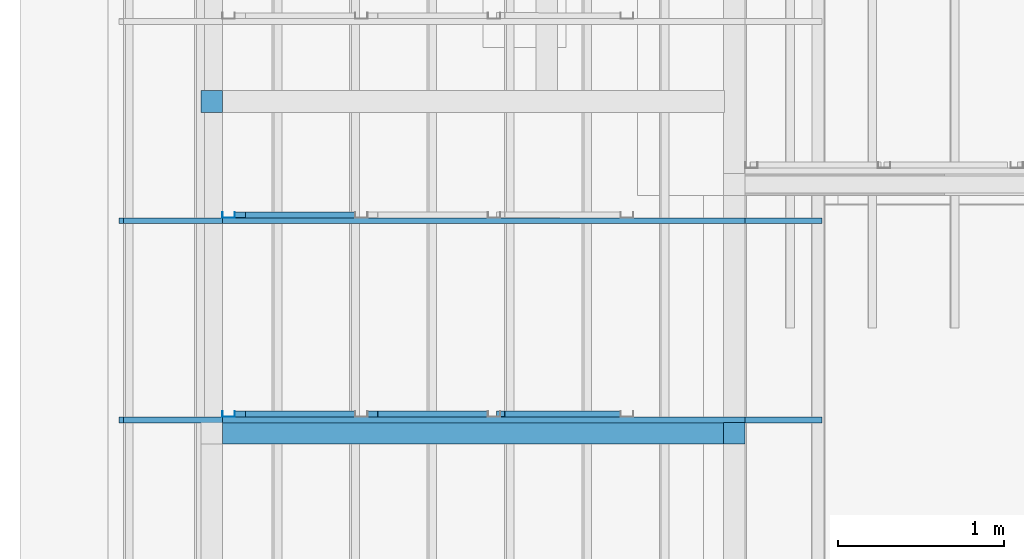
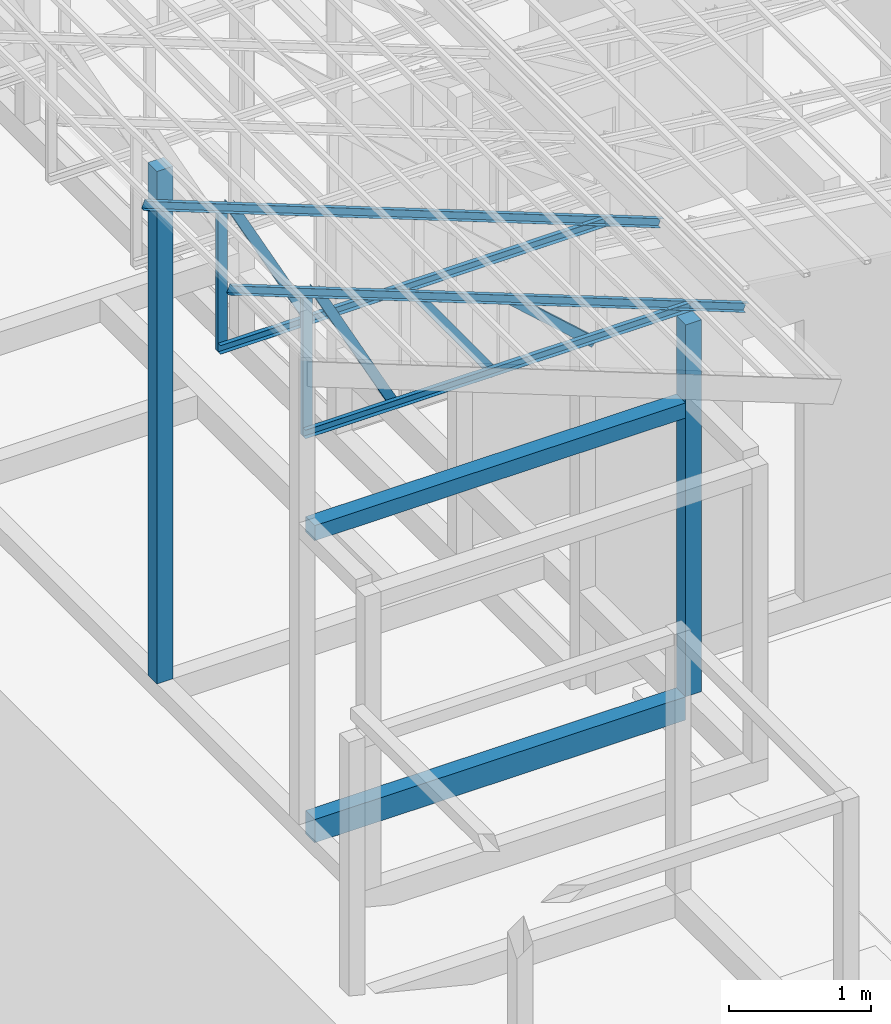
# One storey, part 3 of 22: 10 members, 4 beams, 1 element without a shape of its own.
"""IFC4 building model written with IfcOpenShell, lengths in millimetres."""

from ifc_helpers import new_model, entity, si_unit, converted_unit, frame, origin_with_axes, origin_2d_with_axis, place, context, subcontext, project, spatial, indexed_curve, rectangle, c_section, outline, extrude, material, material_profile, profile_set, profile_usage, type_object, element, aggregate, save


model = new_model("IFC4")

# Units and contexts
model_context = context("Model", 3, precision=1e-05, world=origin_with_axes())
plan_context = context("Plan", 2, precision=1e-05, world=origin_2d_with_axis())
body_context = subcontext(model_context, "Body", "Model", "MODEL_VIEW")
ifc_project = project(units=[si_unit("VOLUMEUNIT", "CUBIC_METRE"), si_unit("LENGTHUNIT", "METRE", prefix="MILLI"), si_unit("AREAUNIT", "SQUARE_METRE"), converted_unit("PLANEANGLEUNIT", "degree", entity("IfcReal", 0.0174532925199433), si_unit("PLANEANGLEUNIT", "RADIAN"), dimensions=[0, 0, 0, 0, 0, 0, 0])], contexts=[model_context, plan_context])

# Site, building, storey
site_placement = place(None, origin_with_axes())
site = spatial("IfcSite", under=ifc_project, at=site_placement)
building_placement = place(site_placement, origin_with_axes())
building = spatial("IfcBuilding", under=site, at=building_placement, Name="2")
storey_placement = place(building_placement, frame((0.0, 0.0, 200.000002980232), z_axis=(0.0, 0.0, 1.0), x_axis=(1.0, 0.0, 0.0)))
storey = spatial("IfcBuildingStorey", under=building, at=storey_placement)

# Beams
ifc_material_1 = material(Name="Concrete")
ifc_material_profile_1 = material_profile(ifc_material_1, outline(indexed_curve([(-65.0, 99.9999923706055), (65.0, 99.9999923706055), (65.0, -99.9999923706055), (-65.0, -99.9999923706055), (-65.0, 99.9999923706055)])))
ifc_profile_set_1 = profile_set([ifc_material_profile_1])
ifc_profile_usage_1 = profile_usage(ifc_profile_set_1, cardinal=2)
beam_type_1 = type_object("IfcBeamType", PredefinedType="BEAM", material=ifc_profile_set_1)
beam_1_placement = place(storey_placement, frame((-7084.9986076355, 5000.0, 535.000070929528), z_axis=(0.999999999999932, -1.9470714107682e-07, 3.13916473260157e-07), x_axis=(1.94707183709391e-07, 0.99999999999997, -1.49011611938472e-07)))
element("IfcBeam", 1, at=beam_1_placement, inside=storey, type_object=beam_type_1, material=ifc_profile_usage_1, Name="Beam", PredefinedType="BEAM", context=body_context, shape_type="SweptSolid", body=[
    extrude(outline(indexed_curve([(-65.0, 99.9999923706055), (65.0, 99.9999923706055), (65.0, -99.9999923706055), (-65.0, -99.9999923706055), (-65.0, 99.9999923706055)])), frame((0.0, 100.0, 0.0), z_axis=(0.0, 0.0, 1.0), x_axis=(1.0, 0.0, 0.0)), (0.0, 0.0, 1.0), 3020.0033867421),
])
ifc_material_profile_2 = material_profile(ifc_material_1, rectangle(XDim=130.000015258789, YDim=130.000015258789, kind="CURVE"))
ifc_profile_set_2 = profile_set([ifc_material_profile_2])
ifc_profile_usage_2 = profile_usage(ifc_profile_set_2, cardinal=5)
beam_type_2 = type_object("IfcBeamType", PredefinedType="BEAM", material=ifc_profile_set_2)
beam_2_placement = place(storey_placement, frame((-3999.99761581421, 5000.0, 735.001966357231), z_axis=(0.0, 0.0, 1.0), x_axis=(1.0, 0.0, 0.0)))
element("IfcBeam", 2, at=beam_2_placement, inside=storey, type_object=beam_type_2, material=ifc_profile_usage_2, Name="Column", PredefinedType="BEAM", context=body_context, shape_type="SweptSolid", body=[
    extrude(rectangle(XDim=130.000015258789, YDim=130.000015258789, kind="CURVE"), origin_with_axes(), (0.0, 0.0, 1.0), 3199.94736270528),
])
ifc_profile_usage_3 = profile_usage(ifc_profile_set_2, cardinal=5)
beam_3_placement = place(storey_placement, frame((-7150.00057220459, 7000.00047683716, 735.000118613243), z_axis=(0.0, 0.0, 1.0), x_axis=(1.0, 0.0, 0.0)))
element("IfcBeam", 3, at=beam_3_placement, inside=storey, type_object=beam_type_2, material=ifc_profile_usage_3, Name="Column", PredefinedType="BEAM", context=body_context, shape_type="SweptSolid", body=[
    extrude(rectangle(XDim=130.000015258789, YDim=130.000015258789, kind="CURVE"), origin_with_axes(), (0.0, 0.0, 1.0), 4411.20902133499),
])
ifc_material_profile_3 = material_profile(ifc_material_1, rectangle(XDim=130.000015258789, YDim=130.000015258789))
ifc_profile_set_3 = profile_set([ifc_material_profile_3])
ifc_profile_usage_4 = profile_usage(ifc_profile_set_3)
beam_type_3 = type_object("IfcBeamType", Name="Ring", PredefinedType="BEAM", material=ifc_profile_set_3)
beam_4_placement = place(storey_placement, frame((-7084.9986076355, 5000.0, 3200.00271499157), z_axis=(0.999999999999932, -1.9470714107682e-07, 3.13916473260157e-07), x_axis=(1.94707183709391e-07, 0.99999999999997, -1.49011611938472e-07)))
element("IfcBeam", 4, at=beam_4_placement, inside=storey, type_object=beam_type_3, material=ifc_profile_usage_4, Name="Beam", PredefinedType="BEAM", context=body_context, shape_type="SweptSolid", body=[
    extrude(rectangle(XDim=130.000015258789, YDim=130.000015258789), origin_with_axes(), (0.0, 0.0, 1.0), 3019.99991309583),
])

# Assembly, members
assembly_placement = place(storey_placement, frame((-3938.51041793823, 5099.00283813477, 3935.3459328413), z_axis=(0.0, 0.0, 1.0), x_axis=(1.0, 0.0, 0.0)))
assembly = element("IfcElementAssembly", 5, at=assembly_placement, inside=storey, Name="2")
ifc_material_2 = material(Name="STEEL")
ifc_material_profile_4 = material_profile(ifc_material_2, c_section(Depth=75.0, Width=35.0, WallThickness=1.0, Girth=1.0, kind="CURVE"))
ifc_profile_set_4 = profile_set([ifc_material_profile_4])
ifc_profile_usage_5 = profile_usage(ifc_profile_set_4, cardinal=1)
member_type = type_object("IfcMemberType", Name="C75", PredefinedType="CHORD", material=ifc_profile_set_4)
member_1_placement = place(assembly_placement, frame((438.234329223633, -34.9993705749512, -169.034004211426), z_axis=(-0.933001152035968, -8.32115964913738e-07, 0.359873380925658), x_axis=(9.09962921013707e-07, -0.999999999999585, 4.6906695416718e-08)))
member_1 = element("IfcMember", 6, at=member_1_placement, type_object=member_type, material=ifc_profile_usage_5, Name="Member", context=body_context, shape_type="SweptSolid", body=[
    extrude(c_section(Depth=75.0, Width=35.0, WallThickness=1.0, Girth=1.0, kind="CURVE"), frame((-17.5, 37.5, 0.0), z_axis=(0.0, 0.0, 1.0), x_axis=(1.0, 0.0, 0.0)), (0.0, 0.0, 1.0), 4510.0754953159),
])
ifc_profile_usage_6 = profile_usage(ifc_profile_set_4, cardinal=1)
member_2_placement = place(assembly_placement, frame((3.51285934448242, -34.9998474121094, -1.35517120361328), z_axis=(-0.999999999999812, -4.33125762810878e-07, 4.33125762810878e-07), x_axis=(4.33125762810919e-07, -0.999999999999906, -1.13742348872837e-13)))
member_2 = element("IfcMember", 7, at=member_2_placement, type_object=member_type, material=ifc_profile_usage_6, Name="Member", context=body_context, shape_type="SweptSolid", body=[
    extrude(c_section(Depth=75.0, Width=35.0, WallThickness=1.0, Girth=1.0, kind="CURVE"), frame((-17.5, 37.5, 0.0), z_axis=(0.0, 0.0, 1.0), x_axis=(1.0, 0.0, 0.0)), (0.0, 0.0, 1.0), 3150.02386296032),
])
ifc_profile_usage_7 = profile_usage(ifc_profile_set_4, cardinal=1)
member_3_placement = place(assembly_placement, frame((-3146.51107788086, 34.998893737793, 1265.15865325928), z_axis=(-8.74227410463377e-08, -1.50995830949794e-07, -0.999999999999985), x_axis=(-3.13916473260159e-07, 0.999999999999939, -1.50995802528077e-07)))
member_3 = element("IfcMember", 8, at=member_3_placement, type_object=member_type, material=ifc_profile_usage_7, Name="Member", context=body_context, shape_type="SweptSolid", body=[
    extrude(c_section(Depth=75.0, Width=35.0, WallThickness=1.0, Girth=1.0, kind="CURVE"), frame((-17.5, 37.5, 0.0), z_axis=(0.0, 0.0, 1.0), x_axis=(1.0, 0.0, 0.0)), (0.0, 0.0, 1.0), 1266.51238309135),
])
ifc_profile_usage_8 = profile_usage(ifc_profile_set_4, cardinal=7)
member_4_placement = place(assembly_placement, frame((-1445.26290893555, 35.9611511230469, 624.074935913086), z_axis=(0.745142107017777, -0.00102660805644996, -0.66690493057482), x_axis=(0.00137753843534741, 0.999999051193456, -2.17762747561669e-07)))
member_4 = element("IfcMember", 9, at=member_4_placement, type_object=member_type, material=ifc_profile_usage_8, Name="Member", context=body_context, shape_type="SweptSolid", body=[
    extrude(c_section(Depth=75.0, Width=35.0, WallThickness=1.0, Girth=1.0, kind="CURVE"), frame((-17.5, -37.5, 0.0), z_axis=(0.0, 0.0, 1.0), x_axis=(1.0, 0.0, 0.0)), (0.0, 0.0, 1.0), 937.808496265298),
])
ifc_profile_usage_9 = profile_usage(ifc_profile_set_4, cardinal=9)
member_5_placement = place(assembly_placement, frame((-3006.42156600952, -0.00095367431640625, 1241.45650863647), z_axis=(0.468464370953309, -3.43728484817469e-07, -0.88348238983423), x_axis=(6.7154434191237e-07, 0.999999999999774, -3.29761675743537e-08)))
member_5 = element("IfcMember", 10, at=member_5_placement, type_object=member_type, material=ifc_profile_usage_9, Name="Member", context=body_context, shape_type="SweptSolid", body=[
    extrude(c_section(Depth=75.0, Width=35.0, WallThickness=1.0, Girth=1.0, kind="CURVE"), frame((17.5, -37.5, 0.0), z_axis=(0.0, 0.0, 1.0), x_axis=(1.0, 0.0, 0.0)), (0.0, 0.0, 1.0), 1399.63894386164),
])
ifc_profile_usage_10 = profile_usage(ifc_profile_set_4, cardinal=3)
member_6_placement = place(assembly_placement, frame((-2271.51107788086, -0.000476837158203125, 894.618034362793), z_axis=(0.578723368640778, -7.49756619914683e-07, -0.815523919078103), x_axis=(1.02917226740772e-06, 0.999999999999453, -1.89020340712783e-07)))
member_6 = element("IfcMember", 11, at=member_6_placement, type_object=member_type, material=ifc_profile_usage_10, Name="Member", context=body_context, shape_type="SweptSolid", body=[
    extrude(c_section(Depth=75.0, Width=35.0, WallThickness=1.0, Girth=1.0, kind="CURVE"), frame((17.5, 37.5, 0.0), z_axis=(0.0, 0.0, 1.0), x_axis=(1.0, 0.0, 0.0)), (0.0, 0.0, 1.0), 1142.30360336039),
])
ifc_profile_usage_11 = profile_usage(ifc_profile_set_4, cardinal=1)
member_7_placement = place(assembly_placement, frame((438.234329223633, 1165.00091552734, -169.034004211426), z_axis=(-0.933001152035968, -8.32115964913738e-07, 0.359873380925658), x_axis=(9.09962921013707e-07, -0.999999999999585, 4.6906695416718e-08)))
member_7 = element("IfcMember", 12, at=member_7_placement, type_object=member_type, material=ifc_profile_usage_11, Name="Member", context=body_context, shape_type="SweptSolid", body=[
    extrude(c_section(Depth=75.0, Width=35.0, WallThickness=1.0, Girth=1.0, kind="CURVE"), frame((-17.5, 37.5, 0.0), z_axis=(0.0, 0.0, 1.0), x_axis=(1.0, 0.0, 0.0)), (0.0, 0.0, 1.0), 4510.0754953159),
])
ifc_profile_usage_12 = profile_usage(ifc_profile_set_4, cardinal=1)
member_8_placement = place(assembly_placement, frame((-3146.51107788086, 1234.99870300293, 1265.15865325928), z_axis=(-8.74227410463377e-08, -1.50995830949794e-07, -0.999999999999985), x_axis=(-3.13916473260159e-07, 0.999999999999939, -1.50995802528077e-07)))
member_8 = element("IfcMember", 13, at=member_8_placement, type_object=member_type, material=ifc_profile_usage_12, Name="Member", context=body_context, shape_type="SweptSolid", body=[
    extrude(c_section(Depth=75.0, Width=35.0, WallThickness=1.0, Girth=1.0, kind="CURVE"), frame((-17.5, 37.5, 0.0), z_axis=(0.0, 0.0, 1.0), x_axis=(1.0, 0.0, 0.0)), (0.0, 0.0, 1.0), 1266.51238309135),
])
ifc_profile_usage_13 = profile_usage(ifc_profile_set_4, cardinal=9)
member_9_placement = place(assembly_placement, frame((-3006.42156600952, 1199.99885559082, 1241.45650863647), z_axis=(0.468464370953309, -3.43728484817469e-07, -0.88348238983423), x_axis=(6.7154434191237e-07, 0.999999999999774, -3.29761675743537e-08)))
member_9 = element("IfcMember", 14, at=member_9_placement, type_object=member_type, material=ifc_profile_usage_13, Name="Member", context=body_context, shape_type="SweptSolid", body=[
    extrude(c_section(Depth=75.0, Width=35.0, WallThickness=1.0, Girth=1.0, kind="CURVE"), frame((17.5, -37.5, 0.0), z_axis=(0.0, 0.0, 1.0), x_axis=(1.0, 0.0, 0.0)), (0.0, 0.0, 1.0), 1399.63894386164),
])
ifc_profile_usage_14 = profile_usage(ifc_profile_set_4, cardinal=1)
member_10_placement = place(assembly_placement, frame((3.51285934448242, 1164.99996185303, -1.35517120361328), z_axis=(-0.999999999999812, -4.33125762810878e-07, 4.33125762810878e-07), x_axis=(4.33125762810919e-07, -0.999999999999906, -1.13742348872837e-13)))
member_10 = element("IfcMember", 15, at=member_10_placement, type_object=member_type, material=ifc_profile_usage_14, Name="Member", context=body_context, shape_type="SweptSolid", body=[
    extrude(c_section(Depth=75.0, Width=35.0, WallThickness=1.0, Girth=1.0, kind="CURVE"), frame((-17.5, 37.5, 0.0), z_axis=(0.0, 0.0, 1.0), x_axis=(1.0, 0.0, 0.0)), (0.0, 0.0, 1.0), 3150.02386296032),
])
aggregate(assembly, [member_1, member_2, member_3, member_4, member_5, member_6, member_7, member_8, member_9, member_10])

save(model, "model.ifc")
